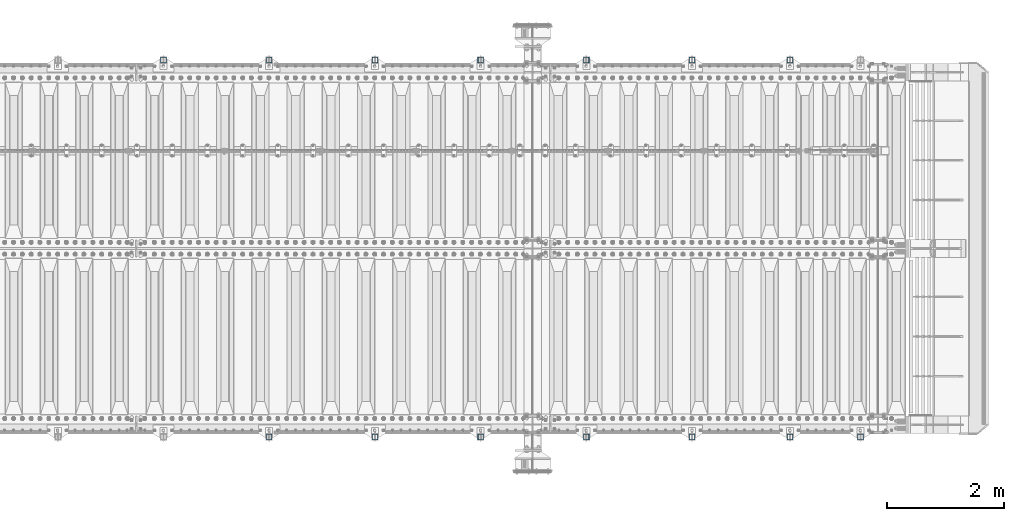
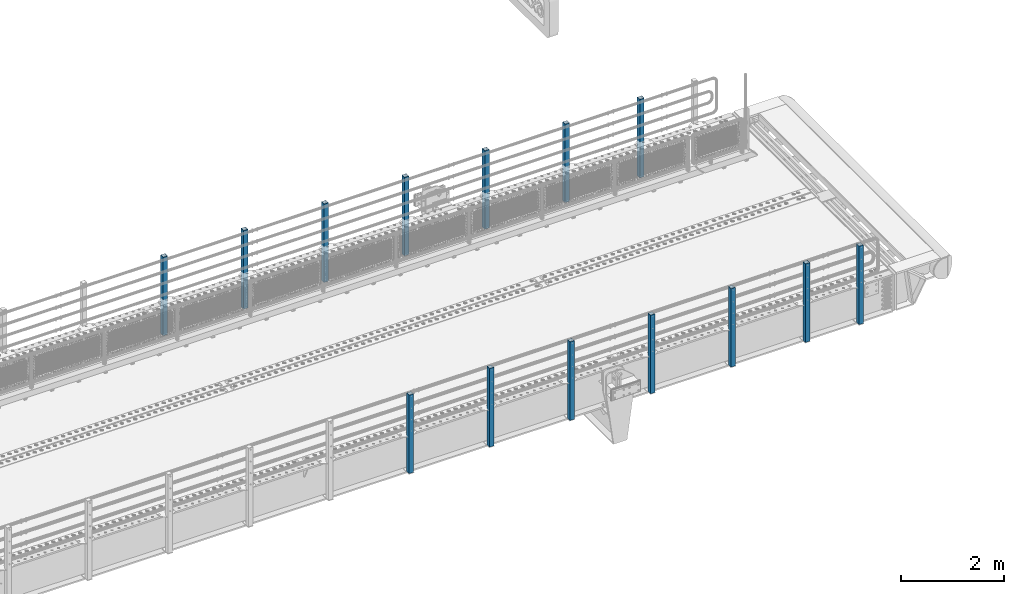
# One storey, part 58 of 242: 14 columns.
"""IFC2X3 building model written with IfcOpenShell, lengths in millimetres."""

from ifc_helpers import new_model, si_unit, frame, origin_with_axes, place, context, subcontext, project, spatial, faceted_brep, material, type_object, element, save


model = new_model("IFC2X3")

# Units and contexts
model_context = context("Model", 3, precision=1e-05, world=origin_with_axes())
body_context = subcontext(model_context, "Body", "Model", "MODEL_VIEW")
ifc_project = project(units=[si_unit("LENGTHUNIT", "METRE", prefix="MILLI"), si_unit("AREAUNIT", "SQUARE_METRE"), si_unit("VOLUMEUNIT", "CUBIC_METRE"), si_unit("MASSUNIT", "GRAM", prefix="KILO"), si_unit("TIMEUNIT", "SECOND"), si_unit("PLANEANGLEUNIT", "RADIAN"), si_unit("SOLIDANGLEUNIT", "STERADIAN"), si_unit("THERMODYNAMICTEMPERATUREUNIT", "DEGREE_CELSIUS"), si_unit("LUMINOUSINTENSITYUNIT", "LUMEN")], contexts=[model_context])

# Site, building, storey
site_placement = place(None, origin_with_axes())
site = spatial("IfcSite", under=ifc_project, at=site_placement, CompositionType="ELEMENT")
building_placement = place(site_placement, origin_with_axes())
building = spatial("IfcBuilding", under=site, at=building_placement, Name="Standard", CompositionType="ELEMENT")
storey_placement = place(building_placement, origin_with_axes())
storey = spatial("IfcBuildingStorey", under=building, at=storey_placement, Name="Undefined", CompositionType="ELEMENT", Elevation=0.0)

# Columns
ifc_material = material()
column_type = type_object("IfcColumnType", PredefinedType="NOTDEFINED")
for number, where, z_axis, x_axis in (
    (1, (-29300.0000000001, -24210.0000000002, -844.999999999998), (0.0, 1.0, 0.0), (0.0, 0.0, 1.0)),
    (2, (-24031.9999999999, -17789.9999999998, -844.999999999998), (0.0, -1.0, 0.0), (0.0, 0.0, 1.0)),
    (3, (-25699.9999999999, -17789.9999999998, -844.999999999998), (0.0, -1.0, 0.0), (0.0, 0.0, 1.0)),
    (4, (-27499.9999999999, -17789.9999999998, -844.999999999998), (0.0, -1.0, 0.0), (0.0, 0.0, 1.0)),
    (5, (-29299.9999999999, -17789.9999999998, -844.999999999998), (0.0, -1.0, 0.0), (0.0, 0.0, 1.0)),
    (6, (-31099.9999999999, -17789.9999999998, -844.999999999998), (0.0, -1.0, 0.0), (0.0, 0.0, 1.0)),
    (7, (-32899.9999999999, -17789.9999999998, -844.999999999998), (0.0, -1.0, 0.0), (0.0, 0.0, 1.0)),
    (8, (-34699.9999999999, -17789.9999999998, -844.999999999998), (0.0, -1.0, 0.0), (0.0, 0.0, 1.0)),
    (9, (-25700.0000000001, -24210.0000000002, -844.999999999998), (0.0, 1.0, 0.0), (0.0, 0.0, 1.0)),
    (10, (-27500.0000000001, -24210.0000000002, -844.999999999998), (0.0, 1.0, 0.0), (0.0, 0.0, 1.0)),
    (11, (-31100.0000000001, -24210.0000000002, -844.999999999998), (0.0, 1.0, 0.0), (0.0, 0.0, 1.0)),
    (12, (-32900.0000000001, -24210.0000000002, -844.999999999998), (0.0, 1.0, 0.0), (0.0, 0.0, 1.0)),
    (13, (-22832.0000000001, -24210.0000000002, -844.999999999998), (0.0, 1.0, 0.0), (0.0, 0.0, 1.0)),
    (14, (-24032.0000000001, -24210.0000000002, -844.999999999998), (0.0, 1.0, 0.0), (0.0, 0.0, 1.0)),
):
    element("IfcColumn", number, at=place(storey_placement, frame(where, z_axis=z_axis, x_axis=x_axis)), inside=storey, type_object=column_type, material=ifc_material, context=body_context, shape_type="Brep", body=[
        faceted_brep([(0.0, 40.0, -40.0), (0.0, -40.0, -40.0), (1855.0, -40.0, -40.0), (1855.0, 40.0, -40.0), (0.0, -40.0, 40.0), (1855.0, -40.0, 40.0), (0.0, 40.0, 40.0), (1855.0, 40.0, 40.0), (0.0, 50.0, -50.0), (0.0, 50.0, 50.0), (1855.0, 50.0, 50.0), (1855.0, 50.0, -50.0), (0.0, -50.0, 50.0), (1855.0, -50.0, 50.0), (0.0, -50.0, -50.0), (1855.0, -50.0, -50.0)], [[[0, 1, 2, 3]], [[1, 4, 5, 2]], [[4, 6, 7, 5]], [[6, 0, 3, 7]], [[8, 9, 10, 11]], [[9, 12, 13, 10]], [[12, 14, 15, 13]], [[14, 8, 11, 15]], [[13, 15, 11, 10], [5, 7, 3, 2]], [[14, 12, 9, 8], [6, 4, 1, 0]]]),
    ])

save(model, "model.ifc")
